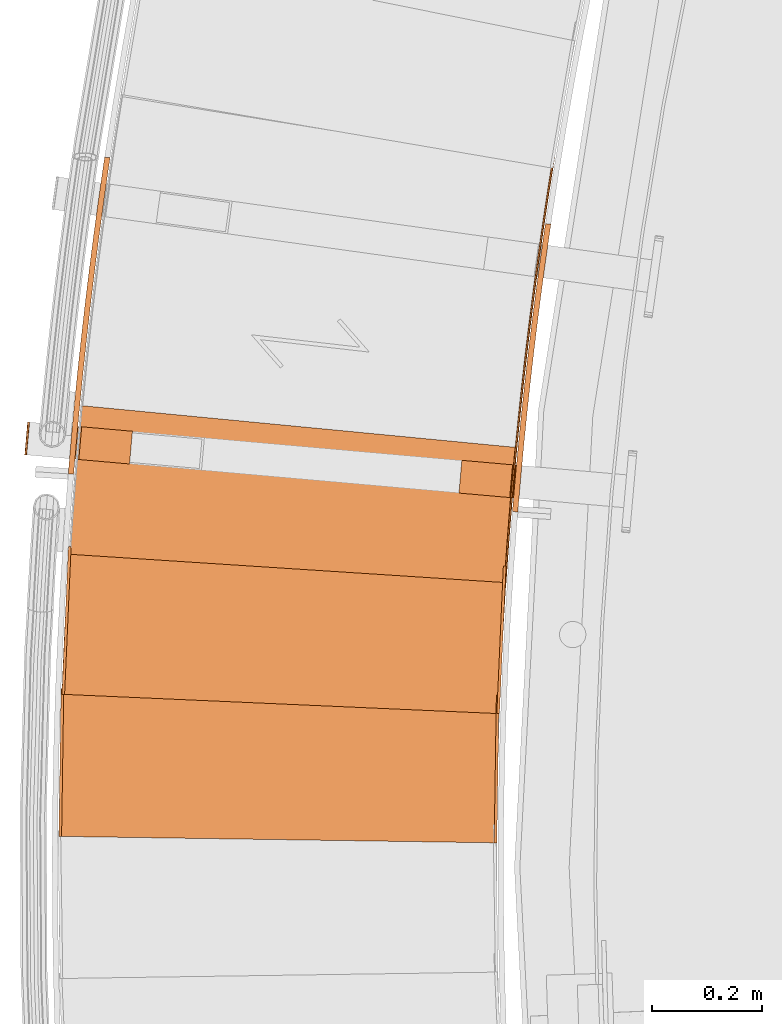
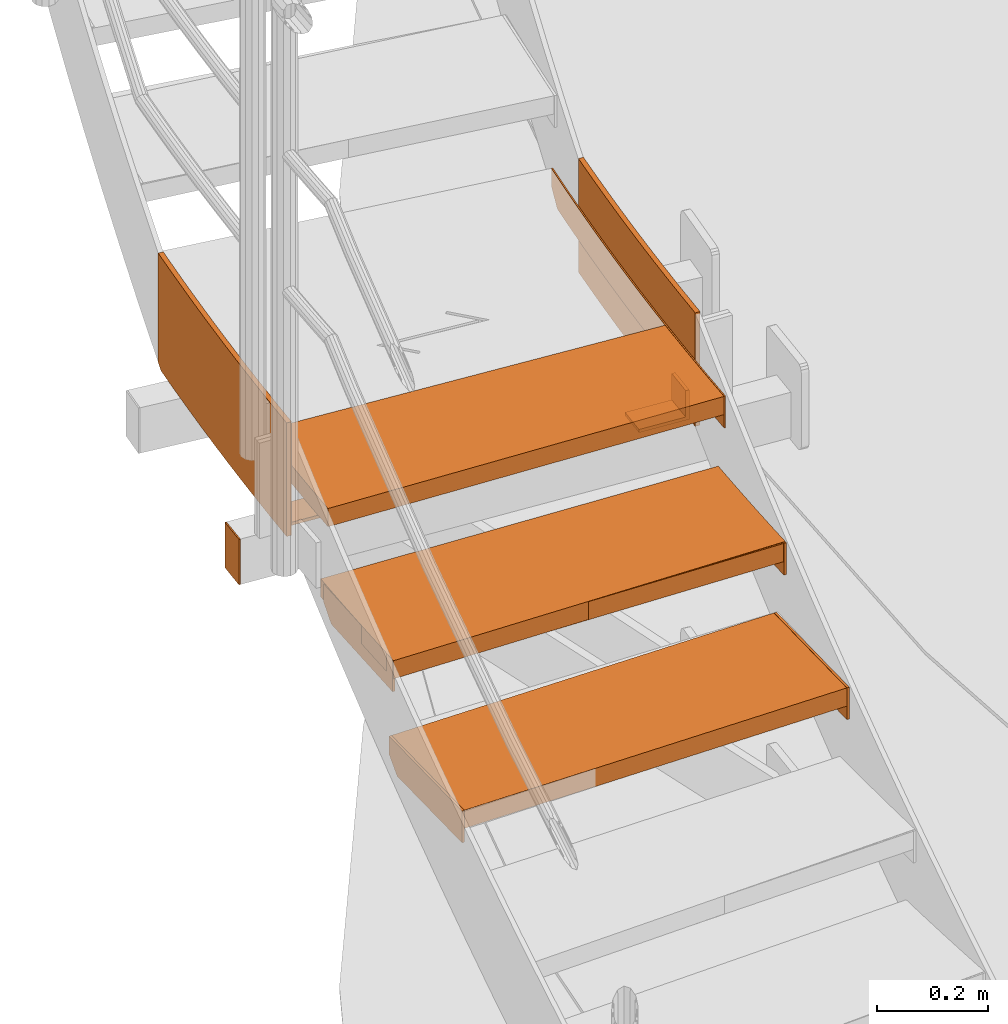
# One storey, part 55 of 126: 14 proxies.
"""IFC2X3 building model written with IfcOpenShell, lengths in millimetres."""

from ifc_helpers import new_model, si_unit, origin, origin_with_axes, place, context, project, spatial, faceted_brep, material, element, save


model = new_model("IFC2X3")

# Units and contexts
context_of_model_1 = context(None, 3, precision=0.1, world=origin())
context_of_model_2 = context(None, 3, precision=0.1, world=origin())
ifc_project = project(units=[si_unit("LENGTHUNIT", "METRE", prefix="MILLI"), si_unit("AREAUNIT", "SQUARE_METRE", prefix="CENTI"), si_unit("VOLUMEUNIT", "CUBIC_METRE", prefix="CENTI"), si_unit("MASSUNIT", "GRAM", prefix="KILO")], contexts=[context_of_model_1, context_of_model_2])

# Site, building, storey
site_placement = place(None, origin_with_axes())
site = spatial("IfcSite", under=ifc_project, at=site_placement, CompositionType="ELEMENT")
building_placement = place(site_placement, origin_with_axes())
building = spatial("IfcBuilding", under=site, at=building_placement, CompositionType="ELEMENT")
storey_placement = place(building_placement, origin_with_axes())
storey = spatial("IfcBuildingStorey", under=building, at=storey_placement, CompositionType="ELEMENT")

# Proxies
ifc_material_1 = material(Name="HOLZ")
proxy_1_placement = place(storey_placement, origin_with_axes())
element("IfcBuildingElementProxy", 1, at=proxy_1_placement, inside=storey, material=ifc_material_1, context=context_of_model_2, shape_type="Brep", body=[
    faceted_brep([(-791.4258, 8606.9822, 5369.3938), (-793.1838, 8580.718, 5369.3938), (-794.8634, 8554.4486, 5369.3938), (-796.4645, 8528.1743, 5369.3938), (-797.9872, 8501.8953, 5369.3938), (-799.4315, 8475.6119, 5369.3938), (-800.7972, 8449.3243, 5369.3938), (-802.0845, 8423.0328, 5369.3938), (-803.2933, 8396.7375, 5369.3938), (-804.4235, 8370.4387, 5369.3938), (-805.4753, 8344.1367, 5369.3938), (-806.4485, 8317.8316, 5369.3938), (-6.9522, 8289.4473, 5369.3938), (-5.9643, 8316.0293, 5369.3938), (-4.8882, 8342.6078, 5369.3938), (-3.724, 8369.1827, 5369.3938), (-2.4715, 8395.7535, 5369.3938), (-1.1309, 8422.32, 5369.3938), (0.2978, 8448.8819, 5369.3938), (1.8146, 8475.439, 5369.3938), (3.4196, 8501.9908, 5369.3938), (5.1126, 8528.5372, 5369.3938), (6.8938, 8555.0778, 5369.3938), (-791.4258, 8606.9822, 5329.3938), (6.8938, 8555.0778, 5329.3938), (5.1126, 8528.5372, 5329.3938), (3.4196, 8501.9908, 5329.3938), (1.8146, 8475.439, 5329.3938), (0.2978, 8448.8819, 5329.3938), (-1.1309, 8422.32, 5329.3938), (-2.4715, 8395.7535, 5329.3938), (-3.724, 8369.1827, 5329.3938), (-4.8882, 8342.6078, 5329.3938), (-5.9643, 8316.0293, 5329.3938), (-6.9522, 8289.4473, 5329.3938), (-806.4485, 8317.8316, 5329.3938), (-805.4753, 8344.1367, 5329.3938), (-804.4235, 8370.4387, 5329.3938), (-803.2933, 8396.7375, 5329.3938), (-802.0845, 8423.0328, 5329.3938), (-800.7972, 8449.3243, 5329.3938), (-799.4315, 8475.6119, 5329.3938), (-797.9872, 8501.8953, 5329.3938), (-796.4645, 8528.1743, 5329.3938), (-794.8634, 8554.4486, 5329.3938), (-793.1838, 8580.718, 5329.3938)], [[[0, 1, 2, 3, 4, 5, 6, 7, 8, 9, 10, 11, 12, 13, 14, 15, 16, 17, 18, 19, 20, 21, 22]], [[23, 24, 25, 26, 27, 28, 29, 30, 31, 32, 33, 34, 35, 36, 37, 38, 39, 40, 41, 42, 43, 44, 45]], [[0, 23, 45, 1]], [[1, 45, 44, 2]], [[2, 44, 43, 3]], [[3, 43, 42, 4]], [[4, 42, 41, 5]], [[5, 41, 40, 6]], [[6, 40, 39, 7]], [[7, 39, 38, 8]], [[8, 38, 37, 9]], [[9, 37, 36, 10]], [[10, 36, 35, 11]], [[11, 35, 34, 12]], [[12, 34, 33, 13]], [[13, 33, 32, 14]], [[14, 32, 31, 15]], [[15, 31, 30, 16]], [[16, 30, 29, 17]], [[17, 29, 28, 18]], [[18, 28, 27, 19]], [[19, 27, 26, 20]], [[20, 26, 25, 21]], [[21, 25, 24, 22]], [[22, 24, 23, 0]]]),
])
proxy_2_placement = place(storey_placement, origin_with_axes())
element("IfcBuildingElementProxy", 2, at=proxy_2_placement, inside=storey, material=ifc_material_1, context=context_of_model_2, shape_type="Brep", body=[
    faceted_brep([(-771.5581, 8848.5148, 5542.6), (-773.8922, 8823.8654, 5542.6), (-776.1571, 8799.2096, 5542.6), (-778.3528, 8774.5475, 5542.6), (-780.4792, 8749.8794, 5542.6), (-782.5363, 8725.2054, 5542.6), (-784.5241, 8700.5257, 5542.6), (-786.4426, 8675.8405, 5542.6), (-788.2917, 8651.15, 5542.6), (-790.0715, 8626.4545, 5542.6), (-791.782, 8601.754, 5542.6), (-793.4231, 8577.0488, 5542.6), (4.8913, 8525.1447, 5542.6), (6.5362, 8549.8545, 5542.6), (8.2574, 8574.559, 5542.6), (10.0549, 8599.258, 5542.6), (11.9287, 8623.9514, 5542.6), (13.8788, 8648.6389, 5542.6), (15.9051, 8673.3203, 5542.6), (18.0076, 8697.9953, 5542.6), (20.1864, 8722.6636, 5542.6), (22.4413, 8747.3252, 5542.6), (24.7724, 8771.9796, 5542.6), (-771.5581, 8848.5148, 5502.6), (24.7724, 8771.9796, 5502.6), (22.4413, 8747.3252, 5502.6), (20.1864, 8722.6636, 5502.6), (18.0076, 8697.9953, 5502.6), (15.9051, 8673.3203, 5502.6), (13.8788, 8648.6389, 5502.6), (11.9287, 8623.9514, 5502.6), (10.0549, 8599.258, 5502.6), (8.2574, 8574.559, 5502.6), (6.5362, 8549.8545, 5502.6), (4.8913, 8525.1447, 5502.6), (-793.4231, 8577.0488, 5502.6), (-791.782, 8601.754, 5502.6), (-790.0715, 8626.4545, 5502.6), (-788.2917, 8651.15, 5502.6), (-786.4426, 8675.8405, 5502.6), (-784.5241, 8700.5257, 5502.6), (-782.5363, 8725.2054, 5502.6), (-780.4792, 8749.8794, 5502.6), (-778.3528, 8774.5475, 5502.6), (-776.1571, 8799.2096, 5502.6), (-773.8922, 8823.8654, 5502.6)], [[[0, 1, 2, 3, 4, 5, 6, 7, 8, 9, 10, 11, 12, 13, 14, 15, 16, 17, 18, 19, 20, 21, 22]], [[23, 24, 25, 26, 27, 28, 29, 30, 31, 32, 33, 34, 35, 36, 37, 38, 39, 40, 41, 42, 43, 44, 45]], [[0, 23, 45, 1]], [[1, 45, 44, 2]], [[2, 44, 43, 3]], [[3, 43, 42, 4]], [[4, 42, 41, 5]], [[5, 41, 40, 6]], [[6, 40, 39, 7]], [[7, 39, 38, 8]], [[8, 38, 37, 9]], [[9, 37, 36, 10]], [[10, 36, 35, 11]], [[11, 35, 34, 12]], [[12, 34, 33, 13]], [[13, 33, 32, 14]], [[14, 32, 31, 15]], [[15, 31, 30, 16]], [[16, 30, 29, 17]], [[17, 29, 28, 18]], [[18, 28, 27, 19]], [[19, 27, 26, 20]], [[20, 26, 25, 21]], [[21, 25, 24, 22]], [[22, 24, 23, 0]]]),
])
ifc_material_2 = material(Name="S235JRG2")
proxy_3_placement = place(storey_placement, origin_with_axes())
element("IfcBuildingElementProxy", 3, at=proxy_3_placement, inside=storey, material=ifc_material_2, context=context_of_model_2, shape_type="Brep", body=[
    faceted_brep([(-806.803, 8061.7497, 5155.59), (-806.803, 8061.7497, 5195.59), (-802.8138, 8331.7202, 5195.59), (-802.8138, 8331.7202, 5155.59), (-16.8892, 8050.0776, 5155.59), (-12.9, 8320.0481, 5155.59), (-12.9, 8320.0481, 5195.59), (-16.8892, 8050.0776, 5195.59)], [[[0, 1, 2, 3]], [[4, 5, 6, 7]], [[0, 4, 7, 1]], [[1, 7, 6, 2]], [[2, 6, 5, 3]], [[3, 5, 4, 0]]]),
])
proxy_4_placement = place(storey_placement, origin_with_axes())
element("IfcBuildingElementProxy", 4, at=proxy_4_placement, inside=storey, material=ifc_material_2, context=context_of_model_2, shape_type="Brep", body=[
    faceted_brep([(-16.8892, 8050.0776, 5125.59), (-11.8898, 8050.0037, 5125.59), (-11.8898, 8050.0037, 5195.59), (-16.8892, 8050.0776, 5195.59), (-12.9, 8320.0481, 5195.59), (-7.9006, 8319.9742, 5195.59), (-7.9006, 8319.9742, 5155.59), (-12.9, 8320.0481, 5155.59), (-13.3433, 8290.0514, 5125.59), (-8.3438, 8289.9775, 5125.59)], [[[0, 1, 2, 3]], [[4, 5, 6, 7]], [[0, 8, 9, 1]], [[1, 9, 6, 5, 2]], [[2, 5, 4, 3]], [[0, 3, 4, 7, 8]], [[6, 9, 8, 7]]]),
])
proxy_5_placement = place(storey_placement, origin_with_axes())
element("IfcBuildingElementProxy", 5, at=proxy_5_placement, inside=storey, material=ifc_material_2, context=context_of_model_2, shape_type="Brep", body=[
    faceted_brep([(-811.8025, 8061.8236, 5125.59), (-806.803, 8061.7497, 5125.59), (-806.803, 8061.7497, 5195.59), (-811.8025, 8061.8236, 5195.59), (-807.8133, 8331.7941, 5195.59), (-802.8138, 8331.7202, 5195.59), (-802.8138, 8331.7202, 5155.59), (-807.8133, 8331.7941, 5155.59), (-808.2565, 8301.7974, 5125.59), (-803.2571, 8301.7235, 5125.59)], [[[0, 1, 2, 3]], [[4, 5, 6, 7]], [[0, 8, 9, 1]], [[1, 9, 6, 5, 2]], [[2, 5, 4, 3]], [[0, 3, 4, 7, 8]], [[6, 9, 8, 7]]]),
])
proxy_6_placement = place(storey_placement, origin_with_axes())
element("IfcBuildingElementProxy", 6, at=proxy_6_placement, inside=storey, material=ifc_material_2, context=context_of_model_2, shape_type="Brep", body=[
    faceted_brep([(-801.3149, 8321.0875, 5328.75), (-801.3149, 8321.0875, 5368.75), (-789.3812, 8590.8236, 5368.75), (-789.3812, 8590.8236, 5328.75), (-12.0869, 8286.1704, 5328.75), (-0.1532, 8555.9066, 5328.75), (-0.1532, 8555.9066, 5368.75), (-12.0869, 8286.1704, 5368.75)], [[[0, 1, 2, 3]], [[4, 5, 6, 7]], [[0, 4, 7, 1]], [[1, 7, 6, 2]], [[2, 6, 5, 3]], [[3, 5, 4, 0]]]),
])
proxy_7_placement = place(storey_placement, origin_with_axes())
element("IfcBuildingElementProxy", 7, at=proxy_7_placement, inside=storey, material=ifc_material_2, context=context_of_model_2, shape_type="Brep", body=[
    faceted_brep([(-12.0869, 8286.1704, 5298.75), (-7.0918, 8285.9495, 5298.75), (-7.0918, 8285.9495, 5368.75), (-12.0869, 8286.1704, 5368.75), (-0.1532, 8555.9066, 5368.75), (4.8419, 8555.6856, 5368.75), (4.8419, 8555.6856, 5328.75), (-0.1532, 8555.9066, 5328.75), (-1.4792, 8525.9359, 5298.75), (3.5159, 8525.7149, 5298.75)], [[[0, 1, 2, 3]], [[4, 5, 6, 7]], [[0, 8, 9, 1]], [[1, 9, 6, 5, 2]], [[2, 5, 4, 3]], [[0, 3, 4, 7, 8]], [[6, 9, 8, 7]]]),
])
proxy_8_placement = place(storey_placement, origin_with_axes())
element("IfcBuildingElementProxy", 8, at=proxy_8_placement, inside=storey, material=ifc_material_2, context=context_of_model_2, shape_type="Brep", body=[
    faceted_brep([(-806.31, 8321.3085, 5298.75), (-801.3149, 8321.0875, 5298.75), (-801.3149, 8321.0875, 5368.75), (-806.31, 8321.3085, 5368.75), (-794.3763, 8591.0446, 5368.75), (-789.3812, 8590.8236, 5368.75), (-789.3812, 8590.8236, 5328.75), (-794.3763, 8591.0446, 5328.75), (-795.7023, 8561.0739, 5298.75), (-790.7072, 8560.8529, 5298.75)], [[[0, 1, 2, 3]], [[4, 5, 6, 7]], [[0, 8, 9, 1]], [[1, 9, 6, 5, 2]], [[2, 5, 4, 3]], [[0, 3, 4, 7, 8]], [[6, 9, 8, 7]]]),
])
proxy_9_placement = place(storey_placement, origin_with_axes())
element("IfcBuildingElementProxy", 9, at=proxy_9_placement, inside=storey, material=ifc_material_2, context=context_of_model_2, shape_type="Brep", body=[
    faceted_brep([(17.1629, 8664.5271, 5392.55), (27.129, 8663.7043, 5392.55), (26.3848, 8654.2892, 5392.55), (16.4049, 8654.938, 5392.55), (27.129, 8663.7043, 5642.55), (26.3848, 8654.2892, 5642.55), (17.1629, 8664.5271, 5642.55), (16.4049, 8654.938, 5642.55), (21.9616, 8720.2763, 5392.55), (31.9217, 8719.384, 5392.55), (31.9217, 8719.384, 5642.55), (21.9616, 8720.2763, 5642.55), (27.1493, 8775.9907, 5392.55), (37.1029, 8775.0288, 5392.55), (37.1029, 8775.0288, 5642.55), (27.1493, 8775.9907, 5642.55), (32.7257, 8831.6675, 5392.55), (42.6724, 8830.6361, 5392.55), (42.6724, 8830.6361, 5642.55), (32.7257, 8831.6675, 5642.55), (38.6905, 8887.304, 5392.55), (48.6298, 8886.2033, 5392.55), (48.6298, 8886.2033, 5642.55), (38.6905, 8887.304, 5642.55), (45.0436, 8942.8975, 5392.55), (54.975, 8941.7274, 5392.55), (54.975, 8941.7274, 5642.55), (45.0436, 8942.8975, 5642.55), (51.7845, 8998.4453, 5392.55), (61.7075, 8997.206, 5392.55), (61.7075, 8997.206, 5642.55), (51.7845, 8998.4453, 5642.55), (58.9129, 9053.9447, 5392.55), (68.827, 9052.6361, 5392.55), (68.827, 9052.6361, 5642.55), (58.9129, 9053.9447, 5642.55), (66.4286, 9109.393, 5392.55), (76.3333, 9108.0153, 5392.55), (76.3333, 9108.0153, 5642.55), (66.4286, 9109.393, 5642.55), (74.331, 9164.7875, 5392.55), (84.2258, 9163.3407, 5392.55), (84.2258, 9163.3407, 5642.55), (74.331, 9164.7875, 5642.55), (76.7119, 9180.6827, 5392.55), (86.7259, 9180.0316, 5392.55), (86.7259, 9180.0316, 5642.55), (76.7119, 9180.6827, 5642.55)], [[[0, 1, 2, 3]], [[1, 4, 5, 2]], [[4, 6, 7, 5]], [[0, 3, 7, 6]], [[0, 8, 9, 1]], [[1, 9, 10, 4]], [[4, 10, 11, 6]], [[6, 11, 8, 0]], [[8, 12, 13, 9]], [[9, 13, 14, 10]], [[10, 14, 15, 11]], [[11, 15, 12, 8]], [[12, 16, 17, 13]], [[13, 17, 18, 14]], [[14, 18, 19, 15]], [[15, 19, 16, 12]], [[16, 20, 21, 17]], [[17, 21, 22, 18]], [[18, 22, 23, 19]], [[19, 23, 20, 16]], [[20, 24, 25, 21]], [[21, 25, 26, 22]], [[22, 26, 27, 23]], [[23, 27, 24, 20]], [[24, 28, 29, 25]], [[25, 29, 30, 26]], [[26, 30, 31, 27]], [[27, 31, 28, 24]], [[28, 32, 33, 29]], [[29, 33, 34, 30]], [[30, 34, 35, 31]], [[31, 35, 32, 28]], [[32, 36, 37, 33]], [[33, 37, 38, 34]], [[34, 38, 39, 35]], [[35, 39, 36, 32]], [[36, 40, 41, 37]], [[37, 41, 42, 38]], [[38, 42, 43, 39]], [[39, 43, 40, 36]], [[40, 44, 45, 41]], [[41, 45, 46, 42]], [[42, 46, 47, 43]], [[40, 43, 47, 44]], [[2, 5, 7, 3]], [[44, 47, 46, 45]]]),
])
proxy_10_placement = place(storey_placement, origin_with_axes())
element("IfcBuildingElementProxy", 10, at=proxy_10_placement, inside=storey, material=ifc_material_2, context=context_of_model_2, shape_type="Brep", body=[
    faceted_brep([(-794.112, 8731.511, 5392.55), (-784.1459, 8730.6881, 5392.55), (-784.7522, 8723.0188, 5392.55), (-794.7321, 8723.6677, 5392.55), (-784.1459, 8730.6881, 5642.55), (-784.7522, 8723.0188, 5642.55), (-794.112, 8731.511, 5642.55), (-794.7321, 8723.6677, 5642.55), (-788.8256, 8792.9222, 5392.55), (-778.8655, 8792.0298, 5392.55), (-778.8655, 8792.0298, 5642.55), (-788.8256, 8792.9222, 5642.55), (-783.1107, 8854.295, 5392.55), (-773.157, 8853.333, 5392.55), (-773.157, 8853.333, 5642.55), (-783.1107, 8854.295, 5642.55), (-776.9673, 8915.6264, 5392.55), (-767.0206, 8914.595, 5392.55), (-767.0206, 8914.595, 5642.55), (-776.9673, 8915.6264, 5642.55), (-770.396, 8976.9134, 5392.55), (-760.4567, 8975.8126, 5392.55), (-760.4567, 8975.8126, 5642.55), (-770.396, 8976.9134, 5642.55), (-763.397, 9038.153, 5392.55), (-753.4656, 9036.9828, 5392.55), (-753.4656, 9036.9828, 5642.55), (-763.397, 9038.153, 5642.55), (-755.9706, 9099.3423, 5392.55), (-746.0476, 9098.1028, 5392.55), (-746.0476, 9098.1028, 5642.55), (-755.9706, 9099.3423, 5642.55), (-748.1172, 9160.4783, 5392.55), (-738.2032, 9159.1695, 5392.55), (-738.2032, 9159.1695, 5642.55), (-748.1172, 9160.4783, 5642.55), (-739.8372, 9221.5579, 5392.55), (-729.9325, 9220.18, 5392.55), (-729.9325, 9220.18, 5642.55), (-739.8372, 9221.5579, 5642.55), (-731.131, 9282.5782, 5392.55), (-721.2362, 9281.1312, 5392.55), (-721.2362, 9281.1312, 5642.55), (-731.131, 9282.5782, 5642.55), (-730.233, 9288.5728, 5392.55), (-720.2189, 9287.9217, 5392.55), (-718.1948, 9301.4329, 5401.6603), (-718.1948, 9301.4329, 5642.55), (-728.2089, 9302.0839, 5642.55), (-728.2089, 9302.0839, 5401.6603)], [[[0, 1, 2, 3]], [[1, 4, 5, 2]], [[4, 6, 7, 5]], [[0, 3, 7, 6]], [[0, 8, 9, 1]], [[1, 9, 10, 4]], [[4, 10, 11, 6]], [[6, 11, 8, 0]], [[8, 12, 13, 9]], [[9, 13, 14, 10]], [[10, 14, 15, 11]], [[11, 15, 12, 8]], [[12, 16, 17, 13]], [[13, 17, 18, 14]], [[14, 18, 19, 15]], [[15, 19, 16, 12]], [[16, 20, 21, 17]], [[17, 21, 22, 18]], [[18, 22, 23, 19]], [[19, 23, 20, 16]], [[20, 24, 25, 21]], [[21, 25, 26, 22]], [[22, 26, 27, 23]], [[23, 27, 24, 20]], [[24, 28, 29, 25]], [[25, 29, 30, 26]], [[26, 30, 31, 27]], [[27, 31, 28, 24]], [[28, 32, 33, 29]], [[29, 33, 34, 30]], [[30, 34, 35, 31]], [[31, 35, 32, 28]], [[32, 36, 37, 33]], [[33, 37, 38, 34]], [[34, 38, 39, 35]], [[35, 39, 36, 32]], [[36, 40, 41, 37]], [[37, 41, 42, 38]], [[38, 42, 43, 39]], [[39, 43, 40, 36]], [[40, 44, 45, 41]], [[41, 45, 46, 47, 42]], [[42, 47, 48, 43]], [[40, 43, 48, 49, 44]], [[46, 49, 48, 47]], [[44, 49, 46, 45]], [[2, 5, 7, 3]]]),
])
proxy_11_placement = place(storey_placement, origin_with_axes())
element("IfcBuildingElementProxy", 11, at=proxy_11_placement, inside=storey, material=ifc_material_2, context=context_of_model_2, shape_type="Brep", body=[
    faceted_brep([(1.8976, 8525.3393, 5472.55), (4.8913, 8525.1447, 5472.55), (4.8913, 8525.1447, 5542.55), (1.8976, 8525.3393, 5542.55), (2.4052, 8533.1447, 5472.55), (5.3987, 8532.9471, 5472.55), (5.3987, 8532.9471, 5542.55), (2.4052, 8533.1447, 5542.55), (3.4508, 8548.7534, 5472.55), (6.4439, 8548.55, 5472.55), (6.4439, 8548.55, 5542.55), (3.4508, 8548.7534, 5542.55), (4.5268, 8564.3601, 5472.55), (7.5195, 8564.1508, 5472.55), (7.5195, 8564.1508, 5542.55), (4.5268, 8564.3601, 5542.55), (5.6333, 8579.9646, 5472.55), (8.6256, 8579.7495, 5472.55), (8.6256, 8579.7495, 5542.55), (5.6333, 8579.9646, 5542.55), (6.7702, 8595.5669, 5472.55), (9.7621, 8595.346, 5472.55), (9.7621, 8595.346, 5542.55), (6.7702, 8595.5669, 5542.55), (7.9375, 8611.167, 5472.55), (10.929, 8610.9403, 5472.55), (10.929, 8610.9403, 5542.55), (7.9375, 8611.167, 5542.55), (9.1353, 8626.7648, 5472.55), (12.1263, 8626.5322, 5472.55), (12.1263, 8626.5322, 5542.55), (9.1353, 8626.7648, 5542.55), (10.3635, 8642.3602, 5472.55), (13.354, 8642.1218, 5472.55), (13.354, 8642.1218, 5542.55), (10.3635, 8642.3602, 5542.55), (11.6221, 8657.9532, 5472.55), (14.6121, 8657.7089, 5472.55), (14.6121, 8657.7089, 5542.55), (11.6221, 8657.9532, 5542.55), (12.9111, 8673.5437, 5472.55), (15.9007, 8673.2936, 5472.55), (15.9007, 8673.2936, 5542.55), (12.9111, 8673.5437, 5542.55), (14.2305, 8689.1317, 5472.55), (17.2196, 8688.8758, 5472.55), (17.2196, 8688.8758, 5542.55), (14.2305, 8689.1317, 5542.55), (15.5804, 8704.7171, 5472.55), (18.5689, 8704.4553, 5472.55), (18.5689, 8704.4553, 5542.55), (15.5804, 8704.7171, 5542.55), (16.9606, 8720.2997, 5472.55), (19.9486, 8720.0321, 5472.55), (19.9486, 8720.0321, 5542.55), (16.9606, 8720.2997, 5542.55), (18.3712, 8735.8797, 5472.55), (21.3587, 8735.6063, 5472.55), (21.3587, 8735.6063, 5542.55), (18.3712, 8735.8797, 5542.55), (19.8122, 8751.4569, 5472.55), (22.7992, 8751.1777, 5472.55), (22.7992, 8751.1777, 5542.55), (19.8122, 8751.4569, 5542.55), (21.2836, 8767.0313, 5472.55), (24.2701, 8766.7462, 5472.55), (24.2701, 8766.7462, 5542.55), (21.2836, 8767.0313, 5542.55), (22.7854, 8782.6027, 5472.55), (25.7713, 8782.3118, 5472.55), (25.7713, 8782.3118, 5542.55), (22.7854, 8782.6027, 5542.55), (24.3175, 8798.1712, 5472.55), (27.3028, 8797.8745, 5472.55), (27.3028, 8797.8745, 5542.55), (24.3175, 8798.1712, 5542.55), (25.88, 8813.7367, 5472.55), (28.8647, 8813.4341, 5472.55), (28.8647, 8813.4341, 5542.55), (25.88, 8813.7367, 5542.55), (27.4729, 8829.2991, 5472.55), (30.457, 8828.9907, 5472.55), (30.457, 8828.9907, 5542.55), (27.4729, 8829.2991, 5542.55), (29.0961, 8844.8584, 5472.55), (32.0796, 8844.5442, 5472.55), (32.0796, 8844.5442, 5542.55), (29.0961, 8844.8584, 5542.55), (30.7497, 8860.4144, 5472.55), (33.7326, 8860.0944, 5472.55), (33.7326, 8860.0944, 5542.55), (30.7497, 8860.4144, 5542.55), (32.4336, 8875.9672, 5472.55), (35.4158, 8875.6414, 5472.55), (35.4158, 8875.6414, 5542.55), (32.4336, 8875.9672, 5542.55), (34.1478, 8891.5167, 5472.55), (37.1294, 8891.1851, 5472.55), (37.1294, 8891.1851, 5542.55), (34.1478, 8891.5167, 5542.55), (35.8924, 8907.0629, 5472.55), (38.8733, 8906.7254, 5472.55), (38.8733, 8906.7254, 5542.55), (35.8924, 8907.0629, 5542.55), (37.6672, 8922.6055, 5472.55), (40.6475, 8922.2623, 5472.55), (40.6475, 8922.2623, 5542.55), (37.6672, 8922.6055, 5542.55), (39.4724, 8938.1447, 5472.55), (42.4521, 8937.7957, 5472.55), (42.4521, 8937.7957, 5542.55), (39.4724, 8938.1447, 5542.55), (41.3079, 8953.6804, 5472.55), (44.2869, 8953.3255, 5472.55), (44.2869, 8953.3255, 5542.55), (41.3079, 8953.6804, 5542.55), (43.1738, 8969.2124, 5472.55), (46.152, 8968.8517, 5472.55), (46.152, 8968.8517, 5542.55), (43.1738, 8969.2124, 5542.55), (45.0698, 8984.7408, 5472.55), (48.0474, 8984.3743, 5472.55), (48.0474, 8984.3743, 5542.55), (45.0698, 8984.7408, 5542.55), (46.9962, 9000.2654, 5472.55), (49.973, 8999.8931, 5472.55), (49.973, 8999.8931, 5542.55), (46.9962, 9000.2654, 5542.55), (48.9529, 9015.7863, 5472.55), (51.929, 9015.4082, 5472.55), (51.929, 9015.4082, 5542.55), (48.9529, 9015.7863, 5542.55), (50.9398, 9031.3033, 5472.55), (53.9152, 9030.9194, 5472.55), (53.9152, 9030.9194, 5542.55), (50.9398, 9031.3033, 5542.55), (52.957, 9046.8164, 5472.55), (55.9316, 9046.4267, 5472.55), (55.9316, 9046.4267, 5542.55), (52.957, 9046.8164, 5542.55), (55.0045, 9062.3255, 5472.55), (57.9783, 9061.93, 5472.55), (57.9783, 9061.93, 5542.55), (55.0045, 9062.3255, 5542.55), (57.0822, 9077.8307, 5472.55), (60.0552, 9077.4293, 5472.55), (60.0552, 9077.4293, 5542.55), (57.0822, 9077.8307, 5542.55), (59.1901, 9093.3317, 5472.55), (62.1624, 9092.9246, 5472.55), (62.1624, 9092.9246, 5542.55), (59.1901, 9093.3317, 5542.55), (61.3283, 9108.8286, 5472.55), (64.2997, 9108.4157, 5472.55), (64.2997, 9108.4157, 5542.55), (61.3283, 9108.8286, 5542.55), (63.4967, 9124.3213, 5472.55), (66.4673, 9123.9025, 5472.55), (66.4673, 9123.9025, 5542.55), (63.4967, 9124.3213, 5542.55), (65.6953, 9139.8097, 5472.55), (68.6651, 9139.3852, 5472.55), (68.6651, 9139.3852, 5542.55), (65.6953, 9139.8097, 5542.55), (67.9241, 9155.2938, 5472.55), (70.8931, 9154.8635, 5472.55), (70.8931, 9154.8635, 5542.55), (67.9241, 9155.2938, 5542.55), (70.1831, 9170.7736, 5472.55), (73.1513, 9170.3375, 5472.55), (73.1513, 9170.3375, 5542.55), (70.1831, 9170.7736, 5542.55), (72.4723, 9186.2489, 5472.55), (75.4396, 9185.807, 5472.55), (75.4396, 9185.807, 5542.55), (72.4723, 9186.2489, 5542.55), (74.7917, 9201.7197, 5472.55), (77.7581, 9201.272, 5472.55), (77.7581, 9201.272, 5542.55), (74.7917, 9201.7197, 5542.55), (77.1413, 9217.1859, 5472.55), (80.1068, 9216.7325, 5472.55), (80.1068, 9216.7325, 5542.55), (77.1413, 9217.1859, 5542.55), (79.521, 9232.6476, 5472.55), (82.4856, 9232.1883, 5472.55), (82.4856, 9232.1883, 5542.55), (79.521, 9232.6476, 5542.55), (81.9309, 9248.1045, 5472.55), (84.8946, 9247.6395, 5472.55), (84.8946, 9247.6395, 5542.55), (81.9309, 9248.1045, 5542.55), (84.3709, 9263.5568, 5472.55), (87.3337, 9263.086, 5472.55), (87.3337, 9263.086, 5542.55), (84.3709, 9263.5568, 5542.55), (85.7875, 9272.4157, 5472.55), (88.7944, 9272.2202, 5472.55), (89.803, 9278.5276, 5478.9096), (89.803, 9278.5276, 5542.55), (86.8411, 9279.0042, 5542.55), (86.8411, 9279.0042, 5479.193), (92.3023, 9293.9645, 5494.4761), (92.3023, 9293.9645, 5542.55), (89.3414, 9294.4468, 5542.55), (89.3414, 9294.4468, 5494.7653), (93.5671, 9301.6804, 5502.2579), (93.5671, 9301.6804, 5542.55), (90.6066, 9302.1657, 5542.55), (90.6066, 9302.1657, 5502.55)], [[[0, 1, 2, 3]], [[0, 4, 5, 1]], [[1, 5, 6, 2]], [[2, 6, 7, 3]], [[3, 7, 4, 0]], [[4, 8, 9, 5]], [[5, 9, 10, 6]], [[6, 10, 11, 7]], [[7, 11, 8, 4]], [[8, 12, 13, 9]], [[9, 13, 14, 10]], [[10, 14, 15, 11]], [[11, 15, 12, 8]], [[12, 16, 17, 13]], [[13, 17, 18, 14]], [[14, 18, 19, 15]], [[15, 19, 16, 12]], [[16, 20, 21, 17]], [[17, 21, 22, 18]], [[18, 22, 23, 19]], [[19, 23, 20, 16]], [[20, 24, 25, 21]], [[21, 25, 26, 22]], [[22, 26, 27, 23]], [[23, 27, 24, 20]], [[24, 28, 29, 25]], [[25, 29, 30, 26]], [[26, 30, 31, 27]], [[27, 31, 28, 24]], [[28, 32, 33, 29]], [[29, 33, 34, 30]], [[30, 34, 35, 31]], [[31, 35, 32, 28]], [[32, 36, 37, 33]], [[33, 37, 38, 34]], [[34, 38, 39, 35]], [[35, 39, 36, 32]], [[36, 40, 41, 37]], [[37, 41, 42, 38]], [[38, 42, 43, 39]], [[39, 43, 40, 36]], [[40, 44, 45, 41]], [[41, 45, 46, 42]], [[42, 46, 47, 43]], [[43, 47, 44, 40]], [[44, 48, 49, 45]], [[45, 49, 50, 46]], [[46, 50, 51, 47]], [[47, 51, 48, 44]], [[48, 52, 53, 49]], [[49, 53, 54, 50]], [[50, 54, 55, 51]], [[51, 55, 52, 48]], [[52, 56, 57, 53]], [[53, 57, 58, 54]], [[54, 58, 59, 55]], [[55, 59, 56, 52]], [[56, 60, 61, 57]], [[57, 61, 62, 58]], [[58, 62, 63, 59]], [[59, 63, 60, 56]], [[60, 64, 65, 61]], [[61, 65, 66, 62]], [[62, 66, 67, 63]], [[63, 67, 64, 60]], [[64, 68, 69, 65]], [[65, 69, 70, 66]], [[66, 70, 71, 67]], [[67, 71, 68, 64]], [[68, 72, 73, 69]], [[69, 73, 74, 70]], [[70, 74, 75, 71]], [[71, 75, 72, 68]], [[72, 76, 77, 73]], [[73, 77, 78, 74]], [[74, 78, 79, 75]], [[75, 79, 76, 72]], [[76, 80, 81, 77]], [[77, 81, 82, 78]], [[78, 82, 83, 79]], [[79, 83, 80, 76]], [[80, 84, 85, 81]], [[81, 85, 86, 82]], [[82, 86, 87, 83]], [[83, 87, 84, 80]], [[84, 88, 89, 85]], [[85, 89, 90, 86]], [[86, 90, 91, 87]], [[87, 91, 88, 84]], [[88, 92, 93, 89]], [[89, 93, 94, 90]], [[90, 94, 95, 91]], [[91, 95, 92, 88]], [[92, 96, 97, 93]], [[93, 97, 98, 94]], [[94, 98, 99, 95]], [[95, 99, 96, 92]], [[96, 100, 101, 97]], [[97, 101, 102, 98]], [[98, 102, 103, 99]], [[99, 103, 100, 96]], [[100, 104, 105, 101]], [[101, 105, 106, 102]], [[102, 106, 107, 103]], [[103, 107, 104, 100]], [[104, 108, 109, 105]], [[105, 109, 110, 106]], [[106, 110, 111, 107]], [[107, 111, 108, 104]], [[108, 112, 113, 109]], [[109, 113, 114, 110]], [[110, 114, 115, 111]], [[111, 115, 112, 108]], [[112, 116, 117, 113]], [[113, 117, 118, 114]], [[114, 118, 119, 115]], [[115, 119, 116, 112]], [[116, 120, 121, 117]], [[117, 121, 122, 118]], [[118, 122, 123, 119]], [[119, 123, 120, 116]], [[120, 124, 125, 121]], [[121, 125, 126, 122]], [[122, 126, 127, 123]], [[123, 127, 124, 120]], [[124, 128, 129, 125]], [[125, 129, 130, 126]], [[126, 130, 131, 127]], [[127, 131, 128, 124]], [[128, 132, 133, 129]], [[129, 133, 134, 130]], [[130, 134, 135, 131]], [[131, 135, 132, 128]], [[132, 136, 137, 133]], [[133, 137, 138, 134]], [[134, 138, 139, 135]], [[135, 139, 136, 132]], [[136, 140, 141, 137]], [[137, 141, 142, 138]], [[138, 142, 143, 139]], [[139, 143, 140, 136]], [[140, 144, 145, 141]], [[141, 145, 146, 142]], [[142, 146, 147, 143]], [[143, 147, 144, 140]], [[144, 148, 149, 145]], [[145, 149, 150, 146]], [[146, 150, 151, 147]], [[147, 151, 148, 144]], [[148, 152, 153, 149]], [[149, 153, 154, 150]], [[150, 154, 155, 151]], [[151, 155, 152, 148]], [[152, 156, 157, 153]], [[153, 157, 158, 154]], [[154, 158, 159, 155]], [[155, 159, 156, 152]], [[156, 160, 161, 157]], [[157, 161, 162, 158]], [[158, 162, 163, 159]], [[159, 163, 160, 156]], [[160, 164, 165, 161]], [[161, 165, 166, 162]], [[162, 166, 167, 163]], [[163, 167, 164, 160]], [[164, 168, 169, 165]], [[165, 169, 170, 166]], [[166, 170, 171, 167]], [[167, 171, 168, 164]], [[168, 172, 173, 169]], [[169, 173, 174, 170]], [[170, 174, 175, 171]], [[171, 175, 172, 168]], [[172, 176, 177, 173]], [[173, 177, 178, 174]], [[174, 178, 179, 175]], [[175, 179, 176, 172]], [[176, 180, 181, 177]], [[177, 181, 182, 178]], [[178, 182, 183, 179]], [[179, 183, 180, 176]], [[180, 184, 185, 181]], [[181, 185, 186, 182]], [[182, 186, 187, 183]], [[183, 187, 184, 180]], [[184, 188, 189, 185]], [[185, 189, 190, 186]], [[186, 190, 191, 187]], [[187, 191, 188, 184]], [[188, 192, 193, 189]], [[189, 193, 194, 190]], [[190, 194, 195, 191]], [[191, 195, 192, 188]], [[192, 196, 197, 193]], [[193, 197, 198, 199, 194]], [[194, 199, 200, 195]], [[192, 195, 200, 201, 196]], [[198, 202, 203, 199]], [[199, 203, 204, 200]], [[200, 204, 205, 201]], [[203, 202, 206, 207]], [[203, 207, 208, 204]], [[204, 208, 209, 205]], [[207, 206, 209, 208]], [[196, 201, 205, 209, 206, 202, 198, 197]]]),
])
proxy_12_placement = place(storey_placement, origin_with_axes())
element("IfcBuildingElementProxy", 12, at=proxy_12_placement, inside=storey, material=ifc_material_2, context=context_of_model_2, shape_type="Brep", body=[
    faceted_brep([(-868.5145, 8818.4717, 5292.5501), (-865.5261, 8818.2079, 5292.5501), (-870.8024, 8758.4403, 5292.5501), (-873.7908, 8758.7041, 5292.5501), (-868.5145, 8818.4717, 5392.55), (-873.7908, 8758.7041, 5392.55), (-870.8024, 8758.4403, 5392.55), (-865.5261, 8818.2079, 5392.55)], [[[0, 1, 2, 3]], [[4, 5, 6, 7]], [[0, 4, 7, 1]], [[1, 7, 6, 2]], [[2, 6, 5, 3]], [[3, 5, 4, 0]]]),
])
proxy_13_placement = place(storey_placement, origin_with_axes())
element("IfcBuildingElementProxy", 13, at=proxy_13_placement, inside=storey, material=ifc_material_2, context=context_of_model_2, shape_type="Brep", body=[
    faceted_brep([(18.4008, 8679.9413, 5457.55), (18.4008, 8679.9413, 5392.55), (23.6771, 8739.7089, 5392.55), (23.6771, 8739.7089, 5457.55), (16.7042, 8740.3244, 5457.55), (11.4279, 8680.5569, 5457.55), (16.7042, 8740.3244, 5399.55), (11.4279, 8680.5569, 5399.55), (-75.9355, 8748.5027, 5399.55), (-81.2118, 8688.7351, 5399.55), (-75.9355, 8748.5027, 5392.55), (-81.2118, 8688.7351, 5392.55)], [[[0, 1, 2, 3]], [[0, 3, 4, 5]], [[5, 4, 6, 7]], [[7, 6, 8, 9]], [[9, 8, 10, 11]], [[1, 11, 10, 2]], [[1, 0, 5, 7, 9, 11]], [[3, 2, 10, 8, 6, 4]]]),
])
proxy_14_placement = place(storey_placement, origin_with_axes())
element("IfcBuildingElementProxy", 14, at=proxy_14_placement, inside=storey, material=ifc_material_2, context=context_of_model_2, shape_type="Brep", body=[
    faceted_brep([(-782.3347, 8750.6303, 5457.55), (-777.0584, 8810.3979, 5457.55), (-777.0584, 8810.3979, 5392.55), (-782.3347, 8750.6303, 5392.55), (-775.3618, 8750.0148, 5457.55), (-770.0855, 8809.7823, 5457.55), (-775.3618, 8750.0148, 5399.55), (-770.0855, 8809.7823, 5399.55), (-682.7221, 8741.8365, 5399.55), (-677.4458, 8801.6041, 5399.55), (-682.7221, 8741.8365, 5392.55), (-677.4458, 8801.6041, 5392.55)], [[[0, 1, 2, 3]], [[0, 4, 5, 1]], [[4, 6, 7, 5]], [[6, 8, 9, 7]], [[8, 10, 11, 9]], [[3, 2, 11, 10]], [[3, 10, 8, 6, 4, 0]], [[1, 5, 7, 9, 11, 2]]]),
])

save(model, "model.ifc")
